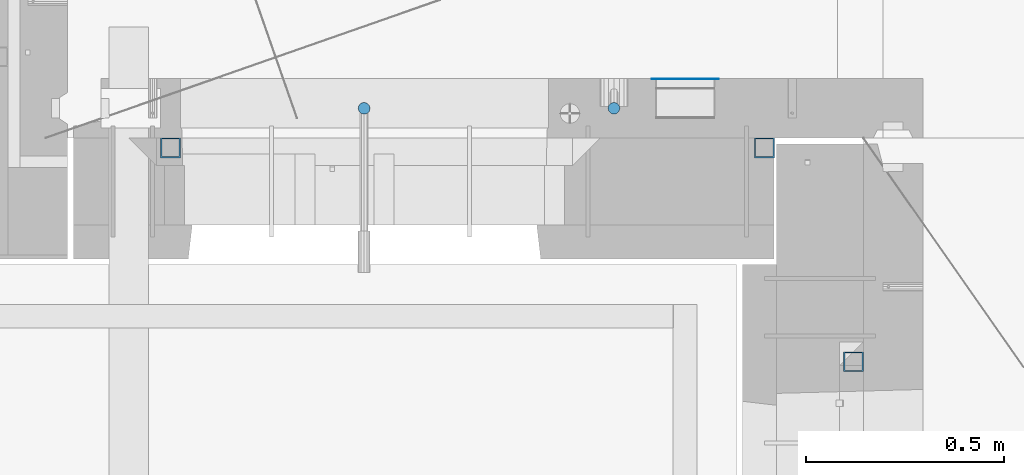
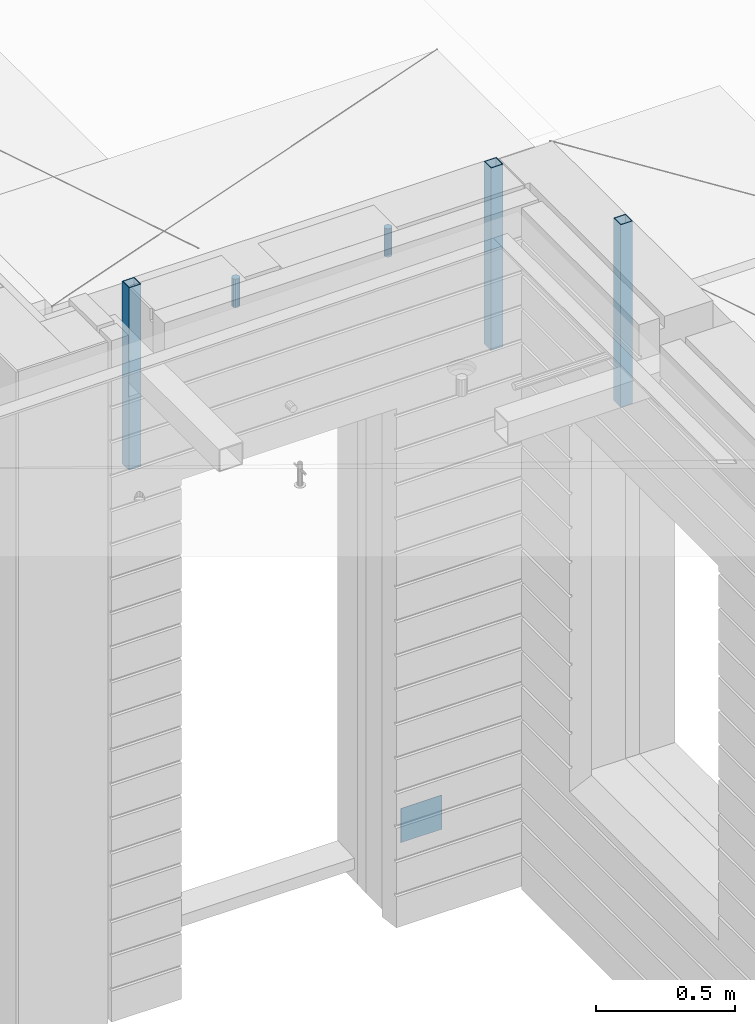
# One storey, part 12 of 341: 6 columns, 6 elements without a shape of their own.
"""IFC2X3 building model written with IfcOpenShell, lengths in millimetres."""

from ifc_helpers import new_model, si_unit, frame, origin_with_axes, place, context, subcontext, project, spatial, faceted_brep, material, type_object, element, aggregate, save


model = new_model("IFC2X3")

# Units and contexts
model_context = context("Model", 3, precision=1e-05, world=origin_with_axes())
body_context = subcontext(model_context, "Body", "Model", "MODEL_VIEW")
ifc_project = project(units=[si_unit("LENGTHUNIT", "METRE", prefix="MILLI"), si_unit("AREAUNIT", "SQUARE_METRE"), si_unit("VOLUMEUNIT", "CUBIC_METRE"), si_unit("MASSUNIT", "GRAM", prefix="KILO"), si_unit("TIMEUNIT", "SECOND"), si_unit("PLANEANGLEUNIT", "RADIAN"), si_unit("SOLIDANGLEUNIT", "STERADIAN"), si_unit("THERMODYNAMICTEMPERATUREUNIT", "DEGREE_CELSIUS"), si_unit("LUMINOUSINTENSITYUNIT", "LUMEN")], contexts=[model_context])

# Site, building, storey
site_placement = place(None, origin_with_axes())
site = spatial("IfcSite", under=ifc_project, at=site_placement, CompositionType="ELEMENT")
building_placement = place(site_placement, origin_with_axes())
building = spatial("IfcBuilding", under=site, at=building_placement, CompositionType="ELEMENT")
storey_placement = place(building_placement, origin_with_axes())
storey = spatial("IfcBuildingStorey", under=building, at=storey_placement, Name="5", CompositionType="ELEMENT", Elevation=0.0)

# Assemblies, columns
assembly_1_placement = place(storey_placement, origin_with_axes())
assembly_1 = element("IfcElementAssembly", 1, at=assembly_1_placement, inside=storey, AssemblyPlace="NOTDEFINED", PredefinedType="REINFORCEMENT_UNIT")
ifc_material_1 = material()
column_type_1 = type_object("IfcColumnType", Name="D30", PredefinedType="NOTDEFINED")
column_1_placement = place(assembly_1_placement, frame((9379.99827996565, 11025.0, 96407.5), z_axis=(0.0, -1.0, 0.0), x_axis=(0.0, 0.0, 1.0)))
column_1 = element("IfcColumn", 2, at=column_1_placement, type_object=column_type_1, material=ifc_material_1, ObjectType="D30", context=body_context, shape_type="Brep", body=[
    faceted_brep([(0.0, -15.0, 0.0), (0.0, -12.9903810567666, -7.5), (125.0, -12.9903810567666, -7.5), (125.0, -15.0, 0.0), (0.0, -7.5, -12.9903810567666), (125.0, -7.5, -12.9903810567666), (0.0, 0.0, -15.0), (125.0, 0.0, -15.0), (0.0, 7.5, -12.9903810567666), (125.0, 7.5, -12.9903810567666), (0.0, 12.9903810567666, -7.5), (125.0, 12.9903810567666, -7.5), (0.0, 15.0, 0.0), (125.0, 15.0, 0.0), (0.0, 12.9903810567666, 7.5), (125.0, 12.9903810567666, 7.5), (0.0, 7.5, 12.9903810567666), (125.0, 7.5, 12.9903810567666), (0.0, 0.0, 15.0), (125.0, 0.0, 15.0), (0.0, -7.5, 12.9903810567666), (125.0, -7.5, 12.9903810567666), (0.0, -12.9903810567666, 7.5), (125.0, -12.9903810567666, 7.5)], [[[0, 1, 2, 3]], [[1, 4, 5, 2]], [[4, 6, 7, 5]], [[6, 8, 9, 7]], [[8, 10, 11, 9]], [[10, 12, 13, 11]], [[12, 14, 15, 13]], [[14, 16, 17, 15]], [[16, 18, 19, 17]], [[18, 20, 21, 19]], [[20, 22, 23, 21]], [[22, 0, 3, 23]], [[5, 7, 9, 11, 13, 15, 17, 19, 21, 23, 3, 2]], [[22, 20, 18, 16, 14, 12, 10, 8, 6, 4, 1, 0]]]),
])
column_2_placement = place(assembly_1_placement, frame((8748.99633326467, 11025.0000000071, 96407.5), z_axis=(0.0, 1.0, 0.0), x_axis=(0.0, 0.0, 1.0)))
column_2 = element("IfcColumn", 3, at=column_2_placement, type_object=column_type_1, material=ifc_material_1, ObjectType="D30", context=body_context, shape_type="Brep", body=[
    faceted_brep([(0.0, -15.0, 0.0), (0.0, -12.9903810567666, -7.5), (125.0, -12.9903810567666, -7.5), (125.0, -15.0, 0.0), (0.0, -7.5, -12.9903810567666), (125.0, -7.5, -12.9903810567666), (0.0, 0.0, -15.0), (125.0, 0.0, -15.0), (0.0, 7.5, -12.9903810567666), (125.0, 7.5, -12.9903810567666), (0.0, 12.9903810567666, -7.5), (125.0, 12.9903810567666, -7.5), (0.0, 15.0, 0.0), (125.0, 15.0, 0.0), (0.0, 12.9903810567666, 7.5), (125.0, 12.9903810567666, 7.5), (0.0, 7.5, 12.9903810567666), (125.0, 7.5, 12.9903810567666), (0.0, 0.0, 15.0), (125.0, 0.0, 15.0), (0.0, -7.5, 12.9903810567666), (125.0, -7.5, 12.9903810567666), (0.0, -12.9903810567666, 7.5), (125.0, -12.9903810567666, 7.5)], [[[0, 1, 2, 3]], [[1, 4, 5, 2]], [[4, 6, 7, 5]], [[6, 8, 9, 7]], [[8, 10, 11, 9]], [[10, 12, 13, 11]], [[12, 14, 15, 13]], [[14, 16, 17, 15]], [[16, 18, 19, 17]], [[18, 20, 21, 19]], [[20, 22, 23, 21]], [[22, 0, 3, 23]], [[5, 7, 9, 11, 13, 15, 17, 19, 21, 23, 3, 2]], [[22, 20, 18, 16, 14, 12, 10, 8, 6, 4, 1, 0]]]),
])
assembly_2_placement = place(assembly_1_placement, origin_with_axes())
assembly_2 = element("IfcElementAssembly", 4, at=assembly_2_placement, Name="Steel Assembly", AssemblyPlace="NOTDEFINED", PredefinedType="NOTDEFINED")
ifc_material_2 = material(Name="Undefined")
column_type_2 = type_object("IfcColumnType", PredefinedType="NOTDEFINED")
column_3_placement = place(assembly_2_placement, frame((9560.0000000031, 11098.9999999984, 93754.9999999985), z_axis=(0.0, 1.0, 0.0), x_axis=(0.0, 0.0, 1.0)))
column_3 = element("IfcColumn", 5, at=column_3_placement, type_object=column_type_2, material=ifc_material_2, Name="SPK2", context=body_context, shape_type="Brep", body=[
    faceted_brep([(0.0, 85.0, -1.0), (0.0, 85.0, 1.0), (150.0, 85.0, 1.0), (150.0, 85.0, -1.0), (0.0, -85.0, 1.0), (150.0, -85.0, 1.0), (0.0, -85.0, -1.0), (150.0, -85.0, -1.0)], [[[0, 1, 2, 3]], [[1, 4, 5, 2]], [[4, 6, 7, 5]], [[6, 0, 3, 7]], [[5, 7, 3, 2]], [[6, 4, 1, 0]]]),
])
aggregate(assembly_2, [column_3])

# Assemblies, column
assembly_3_placement = place(storey_placement, origin_with_axes())
assembly_3 = element("IfcElementAssembly", 6, at=assembly_3_placement, inside=storey, AssemblyPlace="NOTDEFINED", PredefinedType="REINFORCEMENT_UNIT")
assembly_4_placement = place(assembly_3_placement, origin_with_axes())
assembly_4 = element("IfcElementAssembly", 7, at=assembly_4_placement, Name="Steel Assembly", AssemblyPlace="NOTDEFINED", PredefinedType="RIGID_FRAME")
aggregate(assembly_3, [assembly_4])
ifc_material_3 = material(Name="STEEL/S355J2")
column_type_3 = type_object("IfcColumnType", Name="50X50X3", PredefinedType="NOTDEFINED")
column_4_placement = place(assembly_4_placement, frame((9985.0, 10385.0, 95940.0), z_axis=(0.0, 1.0, 0.0), x_axis=(0.0, 0.0, 1.0)))
column_4 = element("IfcColumn", 8, at=column_4_placement, type_object=column_type_3, material=ifc_material_3, ObjectType="50X50X3", context=body_context, shape_type="Brep", body=[
    faceted_brep([(0.0, 22.0, -22.0), (0.0, -22.0, -22.0), (800.0, -22.0, -22.0), (800.0, 22.0, -22.0), (0.0, -22.0, 22.0), (800.0, -22.0, 22.0), (0.0, 22.0, 22.0), (800.0, 22.0, 22.0), (0.0, 25.0, -25.0), (0.0, 25.0, 25.0), (800.0, 25.0, 25.0), (800.0, 25.0, -25.0), (0.0, -25.0, 25.0), (800.0, -25.0, 25.0), (0.0, -25.0, -25.0), (800.0, -25.0, -25.0)], [[[0, 1, 2, 3]], [[1, 4, 5, 2]], [[4, 6, 7, 5]], [[6, 0, 3, 7]], [[8, 9, 10, 11]], [[9, 12, 13, 10]], [[12, 14, 15, 13]], [[14, 8, 11, 15]], [[13, 15, 11, 10], [5, 7, 3, 2]], [[14, 12, 9, 8], [6, 4, 1, 0]]]),
])
aggregate(assembly_4, [column_4])

# Assembly, column
assembly_5_placement = place(assembly_1_placement, origin_with_axes())
assembly_5 = element("IfcElementAssembly", 9, at=assembly_5_placement, Name="Steel Assembly", AssemblyPlace="NOTDEFINED", PredefinedType="RIGID_FRAME")
column_5_placement = place(assembly_5_placement, frame((8260.0, 10925.0, 95940.0), z_axis=(1.0, 0.0, 0.0), x_axis=(0.0, 0.0, 1.0)))
column_5 = element("IfcColumn", 10, at=column_5_placement, type_object=column_type_3, material=ifc_material_3, ObjectType="50X50X3", context=body_context, shape_type="Brep", body=[
    faceted_brep([(0.0, 22.0, -22.0), (0.0, -22.0, -22.0), (800.0, -22.0, -22.0), (800.0, 22.0, -22.0), (0.0, -22.0, 22.0), (800.0, -22.0, 22.0), (0.0, 22.0, 22.0), (800.0, 22.0, 22.0), (0.0, 25.0, -25.0), (0.0, 25.0, 25.0), (800.0, 25.0, 25.0), (800.0, 25.0, -25.0), (0.0, -25.0, 25.0), (800.0, -25.0, 25.0), (0.0, -25.0, -25.0), (800.0, -25.0, -25.0)], [[[0, 1, 2, 3]], [[1, 4, 5, 2]], [[4, 6, 7, 5]], [[6, 0, 3, 7]], [[8, 9, 10, 11]], [[9, 12, 13, 10]], [[12, 14, 15, 13]], [[14, 8, 11, 15]], [[13, 15, 11, 10], [5, 7, 3, 2]], [[14, 12, 9, 8], [6, 4, 1, 0]]]),
])
aggregate(assembly_5, [column_5])

# Assembly
assembly_6_placement = place(assembly_1_placement, origin_with_axes())
assembly_6 = element("IfcElementAssembly", 11, at=assembly_6_placement, Name="Steel Assembly", AssemblyPlace="NOTDEFINED", PredefinedType="RIGID_FRAME")

aggregate(assembly_1, [column_1, column_2, assembly_2, assembly_5, assembly_6])

# Column
column_6_placement = place(assembly_6_placement, frame((9760.0, 10925.0, 95940.0), z_axis=(1.0, 0.0, 0.0), x_axis=(0.0, 0.0, 1.0)))
column_6 = element("IfcColumn", 12, at=column_6_placement, type_object=column_type_3, material=ifc_material_3, ObjectType="50X50X3", context=body_context, shape_type="Brep", body=[
    faceted_brep([(0.0, 22.0, -22.0), (0.0, -22.0, -22.0), (800.0, -22.0, -22.0), (800.0, 22.0, -22.0), (0.0, -22.0, 22.0), (800.0, -22.0, 22.0), (0.0, 22.0, 22.0), (800.0, 22.0, 22.0), (0.0, 25.0, -25.0), (0.0, 25.0, 25.0), (800.0, 25.0, 25.0), (800.0, 25.0, -25.0), (0.0, -25.0, 25.0), (800.0, -25.0, 25.0), (0.0, -25.0, -25.0), (800.0, -25.0, -25.0)], [[[0, 1, 2, 3]], [[1, 4, 5, 2]], [[4, 6, 7, 5]], [[6, 0, 3, 7]], [[8, 9, 10, 11]], [[9, 12, 13, 10]], [[12, 14, 15, 13]], [[14, 8, 11, 15]], [[13, 15, 11, 10], [5, 7, 3, 2]], [[14, 12, 9, 8], [6, 4, 1, 0]]]),
])

aggregate(assembly_6, [column_6])

save(model, "model.ifc")
